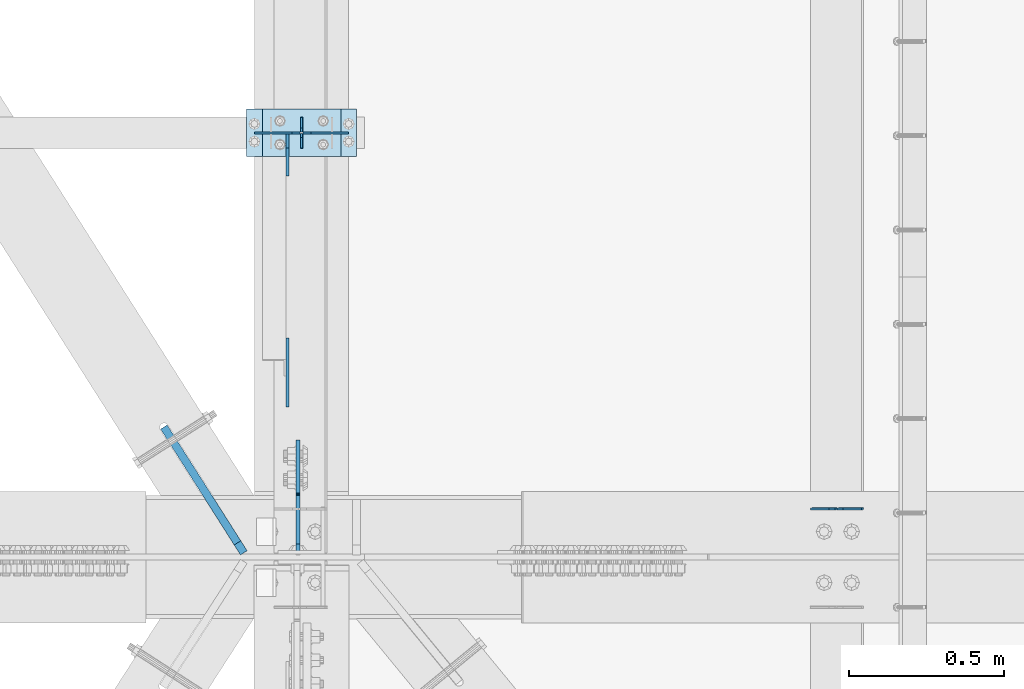
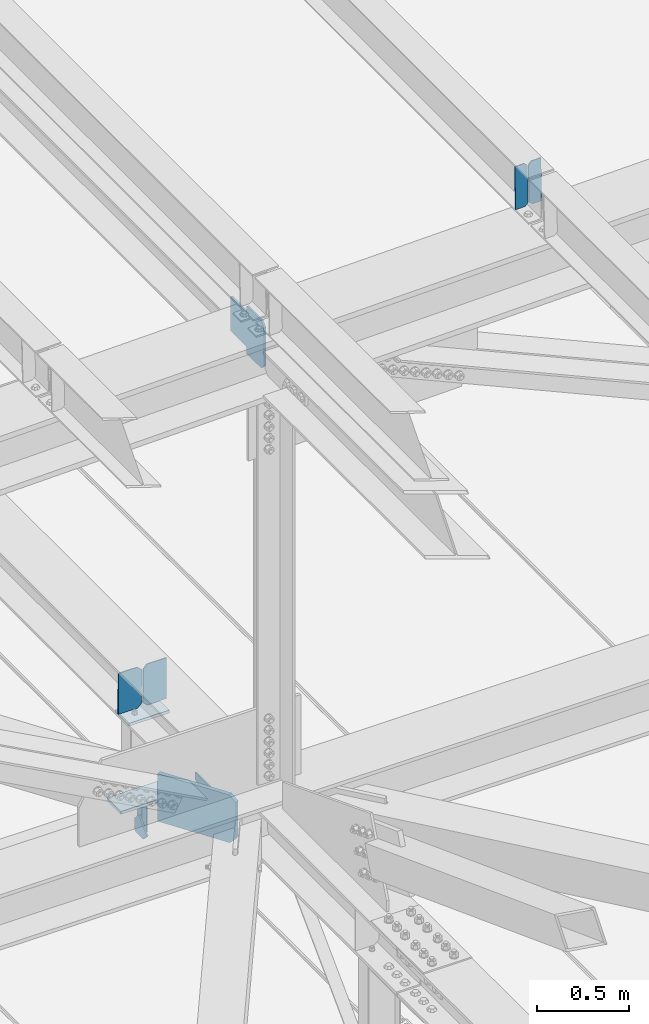
# One storey, part 3222 of 3843: 12 plates, 6 elements without a shape of their own.
"""IFC2X3 building model written with IfcOpenShell, lengths in millimetres."""

from ifc_helpers import new_model, si_unit, frame, origin_with_axes, place, context, subcontext, project, spatial, faceted_brep, material, type_object, element, aggregate, save


model = new_model("IFC2X3")

# Units and contexts
model_context = context("Model", 3, precision=1e-05, world=origin_with_axes())
body_context = subcontext(model_context, "Body", "Model", "MODEL_VIEW")
ifc_project = project(units=[si_unit("LENGTHUNIT", "METRE", prefix="MILLI"), si_unit("AREAUNIT", "SQUARE_METRE"), si_unit("VOLUMEUNIT", "CUBIC_METRE"), si_unit("MASSUNIT", "GRAM", prefix="KILO"), si_unit("TIMEUNIT", "SECOND"), si_unit("PLANEANGLEUNIT", "RADIAN"), si_unit("SOLIDANGLEUNIT", "STERADIAN"), si_unit("THERMODYNAMICTEMPERATUREUNIT", "DEGREE_CELSIUS"), si_unit("LUMINOUSINTENSITYUNIT", "LUMEN")], contexts=[model_context])

# Site, building, storey
site_placement = place(None, origin_with_axes())
site = spatial("IfcSite", under=ifc_project, at=site_placement, CompositionType="ELEMENT")
building_placement = place(site_placement, origin_with_axes())
building = spatial("IfcBuilding", under=site, at=building_placement, Name="Undefined", CompositionType="ELEMENT")
storey_placement = place(building_placement, origin_with_axes())
storey = spatial("IfcBuildingStorey", under=building, at=storey_placement, Name="Undefined", CompositionType="ELEMENT", Elevation=0.0)

# Assembly, plates
assembly_1_placement = place(storey_placement, origin_with_axes())
assembly_1 = element("IfcElementAssembly", 1, at=assembly_1_placement, inside=storey, Name="BEAM", AssemblyPlace="NOTDEFINED", PredefinedType="RIGID_FRAME")
ifc_material = material(Name="STEEL/A572-50")
plate_type_1 = type_object("IfcPlateType", PredefinedType="NOTDEFINED")
plate_1_placement = place(assembly_1_placement, frame((43878.2464782645, 34002.1385582659, 45588.0256511873), z_axis=(-0.0211520980270507, -0.00357224400155975, 0.999769887435027), x_axis=(-0.999776269346825, 7.55769999954079e-05, -0.021151963007321)))
plate_1 = element("IfcPlate", 2, at=plate_1_placement, type_object=plate_type_1, material=ifc_material, Name="PLATE", context=body_context, shape_type="Brep", body=[
    faceted_brep([(0.0, -3.17499999999927, 0.0), (6.83940015733242e-10, -3.17499999996653, 288.924999998613), (6.54836185276508e-10, 3.17500000001746, 288.924999998591), (0.0, 3.17499999999927, 0.0), (60.3250007643655, -3.17500000017753, 288.924999998606), (60.3250007643219, 3.17499999979918, 288.924999998584), (79.3750000013097, -3.17500000025029, 269.875000761494), (79.375000001266, 3.17499999972642, 269.875000761487), (79.375000000713, -3.17500000026484, 19.0499992370605), (79.3750000006985, 3.17499999971187, 19.0499992370533), (60.325000763667, -3.17500000020664, -1.45519152283669e-11), (60.3250007636234, 3.17499999977736, -3.63797880709171e-11)], [[[0, 1, 2, 3]], [[1, 4, 5, 2]], [[4, 6, 7, 5]], [[6, 8, 9, 7]], [[8, 10, 11, 9]], [[10, 0, 3, 11]], [[5, 7, 9, 11, 3, 2]], [[10, 8, 6, 4, 1, 0]]]),
])
plate_2_placement = place(assembly_1_placement, frame((43792.5406575748, 34002.145037135, 45586.21239916), z_axis=(-0.0211520980270507, -0.00357224400155975, 0.999769887435027), x_axis=(-0.999776269346825, 7.55769999954079e-05, -0.021151963007321)))
plate_2 = element("IfcPlate", 3, at=plate_2_placement, type_object=plate_type_1, material=ifc_material, Name="PLATE", context=body_context, shape_type="Brep", body=[
    faceted_brep([(4.36557456851006e-11, -3.17499999998836, 19.0499992370969), (6.11180439591408e-10, -3.17499999996653, 269.875000761516), (5.96628524363041e-10, 3.17500000001746, 269.875000761502), (1.45519152283669e-11, 3.17499999998836, 19.0499992370824), (19.0499992376572, -3.17500000003201, 288.924999998606), (19.0499992376281, 3.1749999999447, 288.924999998584), (79.3750000013242, -3.17500000025029, 288.924999998591), (79.3750000013097, 3.1749999997337, 288.92499999857), (79.3750000006548, -3.17500000026484, -2.18278728425503e-11), (79.3750000006403, 3.17499999969732, -2.91038304567337e-11), (19.0499992370023, -3.17500000005384, 0.0), (19.0499992369587, 3.17499999992287, -1.45519152283669e-11)], [[[0, 1, 2, 3]], [[1, 4, 5, 2]], [[4, 6, 7, 5]], [[6, 8, 9, 7]], [[8, 10, 11, 9]], [[10, 0, 3, 11]], [[5, 7, 9, 11, 3, 2]], [[10, 8, 6, 4, 1, 0]]]),
])
aggregate(assembly_1, [plate_1, plate_2])

assembly_2_placement = place(storey_placement, origin_with_axes())
assembly_2 = element("IfcElementAssembly", 4, at=assembly_2_placement, inside=storey, Name="BEAM", AssemblyPlace="NOTDEFINED", PredefinedType="RIGID_FRAME")
plate_type_2 = type_object("IfcPlateType", PredefinedType="NOTDEFINED")
plate_3_placement = place(assembly_2_placement, frame((42062.4, 35166.3, 41495.6625), z_axis=(0.0, 0.0, -1.0), x_axis=(0.0, 1.0, 0.0)))
plate_3 = element("IfcPlate", 5, at=plate_3_placement, type_object=plate_type_2, material=ifc_material, Name="PLATE", context=body_context, shape_type="Brep", body=[
    faceted_brep([(0.0, -3.17499999999927, 0.0), (0.0, -3.17500000000291, 187.324999999997), (0.0, 3.17500000000291, 187.324999999997), (0.0, 3.17499999999927, 0.0), (34.9250001907349, -3.17500000000291, 187.324999999997), (34.9250001907349, 3.17500000000291, 187.324999999997), (47.625, -3.17500000000291, 174.625000190732), (47.625, 3.17500000000291, 174.625000190732), (47.625, -3.17499999999927, 12.6999998092651), (47.625, 3.17499999999927, 12.6999998092651), (34.9250001907349, -3.17499999999927, 0.0), (34.9250001907349, 3.17499999999927, 0.0)], [[[0, 1, 2, 3]], [[1, 4, 5, 2]], [[4, 6, 7, 5]], [[6, 8, 9, 7]], [[8, 10, 11, 9]], [[10, 0, 3, 11]], [[5, 7, 9, 11, 3, 2]], [[10, 8, 6, 4, 1, 0]]]),
])
plate_4_placement = place(assembly_2_placement, frame((42062.4, 35267.9, 41495.6625), z_axis=(0.0, 0.0, -1.0), x_axis=(0.0, -1.0, 0.0)))
plate_4 = element("IfcPlate", 6, at=plate_4_placement, type_object=plate_type_2, material=ifc_material, Name="PLATE", context=body_context, shape_type="Brep", body=[
    faceted_brep([(0.0, -3.17499999999927, 0.0), (0.0, -3.17500000000291, 187.324999999997), (0.0, 3.17500000000291, 187.324999999997), (0.0, 3.17499999999927, 0.0), (34.9250001907349, -3.17500000000291, 187.324999999997), (34.9250001907349, 3.17500000000291, 187.324999999997), (47.625, -3.17500000000291, 174.625000190732), (47.625, 3.17500000000291, 174.625000190732), (47.625, -3.17499999999927, 12.6999998092651), (47.625, 3.17499999999927, 12.6999998092651), (34.9250001907349, -3.17499999999927, 0.0), (34.9250001907349, 3.17499999999927, 0.0)], [[[0, 1, 2, 3]], [[1, 4, 5, 2]], [[4, 6, 7, 5]], [[6, 8, 9, 7]], [[8, 10, 11, 9]], [[10, 0, 3, 11]], [[5, 7, 9, 11, 3, 2]], [[10, 8, 6, 4, 1, 0]]]),
])

# Assembly, plate
assembly_3_placement = place(storey_placement, origin_with_axes())
assembly_3 = element("IfcElementAssembly", 7, at=assembly_3_placement, inside=storey, Name="BEAM", AssemblyPlace="NOTDEFINED", PredefinedType="RIGID_FRAME")
plate_type_3 = type_object("IfcPlateType", PredefinedType="NOTDEFINED")
plate_5_placement = place(assembly_3_placement, frame((42051.287499852, 33856.6124999999, 45213.0602601614), z_axis=(0.0, 0.707106781186548, 0.707106781186548), x_axis=(5.70000238222118e-08, 0.707106781186546, -0.707106781186546)))
plate_5 = element("IfcPlate", 8, at=plate_5_placement, type_object=plate_type_3, material=ifc_material, Name="PLATE", context=body_context, shape_type="Brep", body=[
    faceted_brep([(0.0, -6.3499999046162, 0.0), (-179.46387894213, -6.35000000000582, 179.46387894213), (-179.46387894213, 6.35000000000582, 179.46387894213), (7.27595761418343e-12, 6.3499999046162, 0.0), (-179.463878941897, -6.35000000000582, 224.365159547495), (-179.463878941897, 6.35000000000582, 224.365159547495), (-68.3332094431244, -6.35000000000582, 335.495829046271), (-68.3332094431244, 6.35000000000582, 335.495829046271), (-46.6340827786098, -6.34999999999854, 313.796702379172), (-46.6340827786098, 6.34999999999854, 313.796702379172), (-42.5139063104671, -6.34999999999854, 311.043688478705), (-42.5139063104671, 6.34999999999854, 311.043688478705), (-37.6538267924316, -6.34999999999854, 310.076958556121), (-37.6538267924316, 6.34999999999854, 310.076958556121), (-32.7937472744034, -6.34999999999854, 311.043688478705), (-32.7937472744034, 6.34999999999854, 311.043688478705), (-28.6735708062533, -6.34999999999854, 313.796702379172), (-28.6735708062533, 6.34999999999854, 313.796702379172), (88.0697589019019, -6.34999999999854, 430.54003208733), (88.0697589019019, 6.34999999999854, 430.54003208733), (249.714369080366, -6.34999999999854, 268.895421908877), (249.714369080366, 6.34999999999854, 268.895421908877), (132.971039372207, -6.34999999999854, 152.152092200718), (132.971039372207, 6.34999999999854, 152.152092200718), (130.218025471737, -6.34999999999854, 148.031915732572), (130.218025471737, 6.34999999999854, 148.031915732572), (129.251295549146, -6.34999999999854, 143.17183621454), (129.251295549146, 6.34999999999854, 143.17183621454), (130.218025471737, -6.34999999999854, 138.311756696508), (130.218025471737, 6.34999999999854, 138.311756696508), (132.971039372203, -6.34999999999854, 134.191580228362), (132.971039372203, 6.34999999999854, 134.191580228362), (156.031950102829, -6.35000000000582, 111.130669497703), (156.031950102829, 6.35000000000582, 111.130669497703), (44.9012806051323, -6.35000000000582, -1.45519152283669e-11), (44.9012806051323, 6.35000000000582, -1.45519152283669e-11)], [[[0, 1, 2, 3]], [[1, 4, 5, 2]], [[4, 6, 7, 5]], [[6, 8, 9, 7]], [[8, 10, 11, 9]], [[10, 12, 13, 11]], [[12, 14, 15, 13]], [[14, 16, 17, 15]], [[16, 18, 19, 17]], [[18, 20, 21, 19]], [[20, 22, 23, 21]], [[22, 24, 25, 23]], [[24, 26, 27, 25]], [[26, 28, 29, 27]], [[28, 30, 31, 29]], [[30, 32, 33, 31]], [[32, 34, 35, 33]], [[34, 0, 3, 35]], [[5, 7, 9, 11, 13, 15, 17, 19, 21, 23, 25, 27, 29, 31, 33, 35, 3, 2]], [[34, 32, 30, 28, 26, 24, 22, 20, 18, 16, 14, 12, 10, 8, 6, 4, 1, 0]]]),
])
aggregate(assembly_3, [plate_5])

# Assembly, plates
assembly_4_placement = place(storey_placement, origin_with_axes())
assembly_4 = element("IfcElementAssembly", 9, at=assembly_4_placement, inside=storey, Name="POST", AssemblyPlace="NOTDEFINED", PredefinedType="RIGID_FRAME")
plate_type_4 = type_object("IfcPlateType", PredefinedType="NOTDEFINED")
plate_6_placement = place(assembly_4_placement, frame((41935.3999970216, 35293.3185511839, 42083.0375), z_axis=(0.0, -1.0, 0.0), x_axis=(1.0, 0.0, 0.0)))
plate_6 = element("IfcPlate", 10, at=plate_6_placement, type_object=plate_type_4, material=ifc_material, Name="PLATE", context=body_context, shape_type="Brep", body=[
    faceted_brep([(0.0, -9.52500000000146, 0.0), (0.0, -9.5249999999287, 152.40000000162), (0.0, 9.52500000002328, 152.40000000162), (0.0, 9.52500000000146, 0.0), (254.0, -9.5249999999287, 152.40000000162), (254.0, 9.52500000002328, 152.40000000162), (253.999999999998, -9.52500000000146, 0.0), (253.999999999998, 9.52500000000146, 0.0)], [[[0, 1, 2, 3]], [[1, 4, 5, 2]], [[4, 6, 7, 5]], [[6, 0, 3, 7]], [[5, 7, 3, 2]], [[6, 4, 1, 0]]]),
])
plate_7_placement = place(assembly_4_placement, frame((42240.2, 35140.9, 41513.125), z_axis=(-1.0, 0.0, 0.0), x_axis=(0.0, 1.0, 0.0)))
plate_7 = element("IfcPlate", 11, at=plate_7_placement, type_object=plate_type_4, material=ifc_material, Name="PLATE", context=body_context, shape_type="Brep", body=[
    faceted_brep([(0.0, -9.52500000000146, 0.0), (0.0, -9.52500000000146, 355.599999999999), (0.0, 9.52500000000146, 355.599999999999), (0.0, 9.52500000000146, 0.0), (152.399999999994, -9.52500000000146, 355.599999999999), (152.399999999994, 9.52500000000146, 355.599999999999), (152.400000000001, -9.52500000000146, 0.0), (152.400000000001, 9.52500000000146, 0.0)], [[[0, 1, 2, 3]], [[1, 4, 5, 2]], [[4, 6, 7, 5]], [[6, 0, 3, 7]], [[5, 7, 3, 2]], [[6, 4, 1, 0]]]),
])
aggregate(assembly_4, [plate_6, plate_7])

# Assembly, plate
assembly_5_placement = place(storey_placement, origin_with_axes())
assembly_5 = element("IfcElementAssembly", 12, at=assembly_5_placement, inside=storey, Name="BEAM", AssemblyPlace="NOTDEFINED", PredefinedType="RIGID_FRAME")
plate_type_5 = type_object("IfcPlateType", PredefinedType="NOTDEFINED")
plate_8_placement = place(assembly_5_placement, frame((42016.3625, 34330.7781094515, 42096.8258679821), z_axis=(0.0, 0.707106781186548, 0.707106781186548), x_axis=(5.70000238222118e-08, 0.707106781186546, -0.707106781186546)))
plate_8 = element("IfcPlate", 13, at=plate_8_placement, type_object=plate_type_5, material=ifc_material, Name="PLATE", context=body_context, shape_type="Brep", body=[
    faceted_brep([(0.0, -4.76249999999709, 0.0), (157.726597423803, -4.76249999999709, 157.726601438866), (157.726597423803, 4.76249999999709, 157.726601438866), (0.0, 4.76249999999709, 0.0), (188.387110059113, -4.76249999999709, 127.066089584019), (188.387110059113, 4.76249999999709, 127.066089584019), (188.387111679331, -4.76249999999709, 1.09139364212751e-10), (188.387111679331, 4.76249999999709, 1.09139364212751e-10)], [[[0, 1, 2, 3]], [[1, 4, 5, 2]], [[4, 6, 7, 5]], [[6, 0, 3, 7]], [[5, 7, 3, 2]], [[6, 4, 1, 0]]]),
])

# Plate
plate_type_6 = type_object("IfcPlateType", PredefinedType="NOTDEFINED")
plate_9_placement = place(assembly_2_placement, frame((42016.3625, 35213.9250000347, 41306.750000025), z_axis=(0.0, -1.0, 0.0), x_axis=(0.0, 0.0, 1.0)))
plate_9 = element("IfcPlate", 14, at=plate_9_placement, type_object=plate_type_6, material=ifc_material, Name="PLATE", context=body_context, shape_type="Brep", body=[
    faceted_brep([(0.0, -4.76250000000073, 12.6999998092651), (4.450703272596e-08, -4.76249999999709, 93.0710244828806), (4.450703272596e-08, 4.76249999999709, 93.0710244828806), (0.0, 4.76250000000073, 12.6999998092651), (43.3137807601452, -4.76249999999709, 136.384805065652), (43.3137807601452, 4.76249999999709, 136.384805065652), (133.209805202001, -4.76249999999709, 46.4887805392646), (133.209805202001, 4.76249999999709, 46.4887805392646), (86.7210245267561, -4.76249999999709, 0.0), (86.7210245267561, 4.76249999999709, 0.0), (12.6999998092651, -4.76250000000073, 0.0), (12.6999998092651, 4.76250000000073, 0.0)], [[[0, 1, 2, 3]], [[1, 4, 5, 2]], [[4, 6, 7, 5]], [[6, 8, 9, 7]], [[8, 10, 11, 9]], [[10, 0, 3, 11]], [[5, 7, 9, 11, 3, 2]], [[10, 8, 6, 4, 1, 0]]]),
])

aggregate(assembly_2, [plate_9, plate_3, plate_4])

plate_type_7 = type_object("IfcPlateType", PredefinedType="NOTDEFINED")
plate_10_placement = place(assembly_5_placement, frame((42214.8, 35216.284259493, 42389.573544389), z_axis=(0.0, 0.00280793599926983, -0.999996057739941), x_axis=(-1.0, 0.0, 0.0)))
plate_10 = element("IfcPlate", 15, at=plate_10_placement, type_object=plate_type_7, material=ifc_material, Name="PLATE", context=body_context, shape_type="Brep", body=[
    faceted_brep([(0.0, -3.17499999999927, 0.0), (0.0, -3.17500000007567, 273.049999997937), (0.0, 3.17499999993743, 273.049999997937), (0.0, 3.17499999999927, 0.0), (122.237500389827, -3.17500000007567, 273.049999997937), (122.237500389827, 3.17499999993743, 273.049999997937), (147.637500008357, -3.17500000006476, 247.650000379464), (147.637500008357, 3.17499999994106, 247.650000379464), (147.637500008357, -3.17500000001382, 25.3999996184648), (147.637500008357, 3.17499999999927, 25.3999996184648), (122.237500389827, -3.17500000000291, 0.0), (122.237500389827, 3.17500000000291, -7.27595761418343e-12)], [[[0, 1, 2, 3]], [[1, 4, 5, 2]], [[4, 6, 7, 5]], [[6, 8, 9, 7]], [[8, 10, 11, 9]], [[10, 0, 3, 11]], [[5, 7, 9, 11, 3, 2]], [[10, 8, 6, 4, 1, 0]]]),
])

plate_11_placement = place(assembly_5_placement, frame((41910.0, 35216.284259493, 42389.573544389), z_axis=(0.0, 0.00280793599926983, -0.999996057739941), x_axis=(1.0, 0.0, 0.0)))
plate_11 = element("IfcPlate", 16, at=plate_11_placement, type_object=plate_type_7, material=ifc_material, Name="PLATE", context=body_context, shape_type="Brep", body=[
    faceted_brep([(0.0, -3.17499999999927, 0.0), (0.0, -3.17500000007567, 273.049999997937), (0.0, 3.17499999993743, 273.049999997937), (0.0, 3.17499999999927, 0.0), (122.237500389827, -3.17500000007567, 273.049999997937), (122.237500389827, 3.17499999993743, 273.049999997937), (147.637500008357, -3.17500000006476, 247.650000379464), (147.637500008357, 3.17499999994106, 247.650000379464), (147.637500008357, -3.17500000001382, 25.3999996184648), (147.637500008357, 3.17499999999927, 25.3999996184648), (122.237500389827, -3.17500000000291, 0.0), (122.237500389827, 3.17500000000291, -7.27595761418343e-12)], [[[0, 1, 2, 3]], [[1, 4, 5, 2]], [[4, 6, 7, 5]], [[6, 8, 9, 7]], [[8, 10, 11, 9]], [[10, 0, 3, 11]], [[5, 7, 9, 11, 3, 2]], [[10, 8, 6, 4, 1, 0]]]),
])

aggregate(assembly_5, [plate_10, plate_11, plate_8])

# Assembly, plate
assembly_6_placement = place(storey_placement, origin_with_axes())
assembly_6 = element("IfcElementAssembly", 17, at=assembly_6_placement, inside=storey, Name="BEAM", AssemblyPlace="NOTDEFINED", PredefinedType="RIGID_FRAME")
plate_type_8 = type_object("IfcPlateType", PredefinedType="NOTDEFINED")
plate_12_placement = place(assembly_6_placement, frame((41875.7358381519, 33859.4536335989, 42090.3587735562), z_axis=(0.0, 0.0, 1.0), x_axis=(-0.536211309998026, 0.844083781996906, 0.0)))
plate_12 = element("IfcPlate", 18, at=plate_12_placement, type_object=plate_type_8, material=ifc_material, Name="STIFFENER", context=body_context, shape_type="Brep", body=[
    faceted_brep([(0.0, -12.6999999999971, 38.0999999999913), (1.57808244694024e-07, -12.7000000000698, 279.400255757311), (1.5777550288476e-07, 12.6999999998807, 279.400255757319), (0.0, 12.6999999999971, 38.0999999999913), (38.0999986533716, -12.7000000000262, 317.500254231185), (38.0999986533352, 12.6999999999243, 317.500254231192), (223.972756430405, -12.6999999997497, 317.50025422997), (223.972756430368, 12.7000000001935, 317.500254229977), (481.637337966346, -12.6999999993786, 317.500254230348), (481.637337966313, 12.7000000005792, 317.500254230355), (481.637337735872, -12.6999999992768, 2.38651409745216e-09), (481.637337735832, 12.7000000006738, 2.39379005506635e-09), (38.1000000000058, -12.7000000000844, 2.18278728425503e-11), (38.1000000000058, 12.7000000000262, 4.36557456851006e-11)], [[[0, 1, 2, 3]], [[1, 4, 5, 2]], [[4, 6, 7, 5]], [[6, 8, 9, 7]], [[8, 10, 11, 9]], [[10, 12, 13, 11]], [[12, 0, 3, 13]], [[5, 7, 9, 11, 13, 3, 2]], [[12, 10, 8, 6, 4, 1, 0]]]),
])
aggregate(assembly_6, [plate_12])

save(model, "model.ifc")
